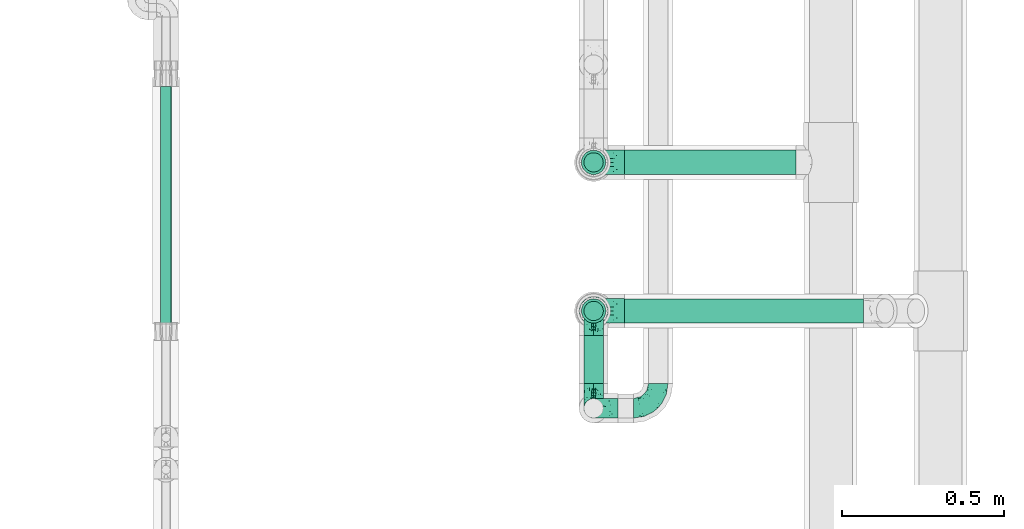
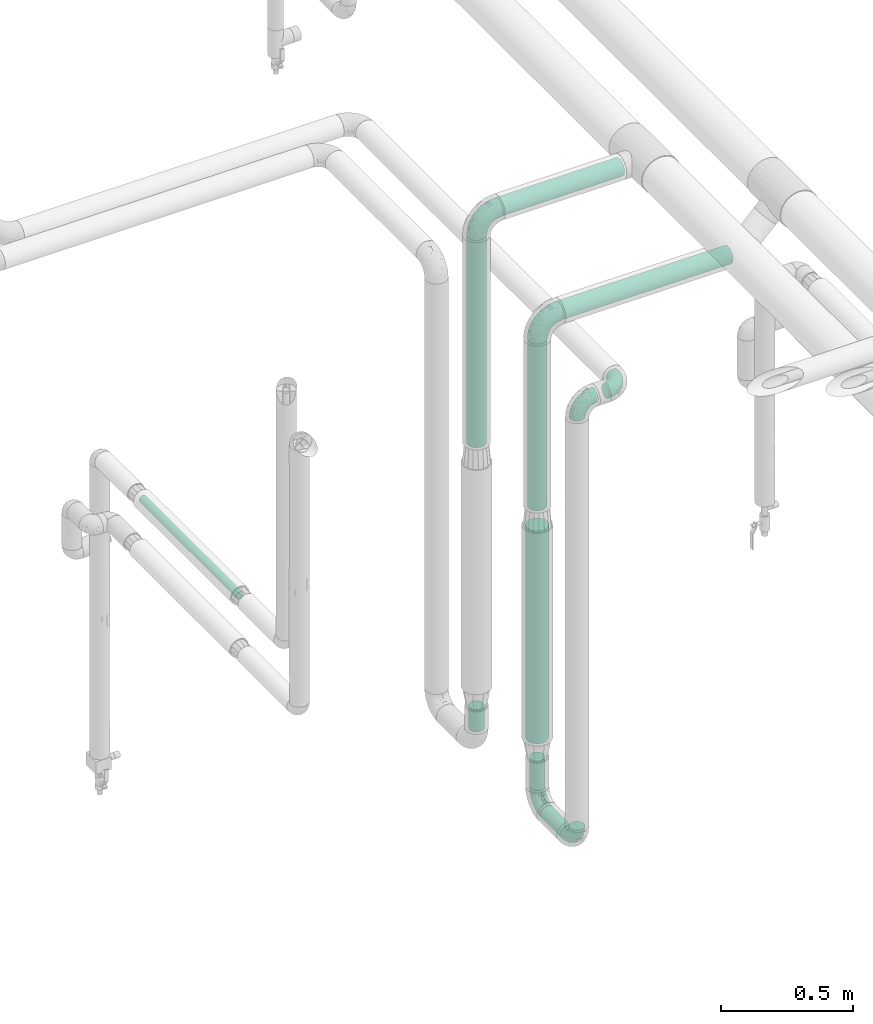
# One storey, part 553 of 827: 9 flow segments, 6 flow fittings.
"""IFC2X3 building model written with IfcOpenShell, lengths in millimetres."""

from ifc_helpers import new_model, entity, si_unit, converted_unit, derived_unit, direction, frame, origin, origin_2d_with_axis, place, context, subcontext, project, spatial, circle, extrude, faceted_brep, source, transform, mapped, material, type_object, type_shapes, element, save


model = new_model("IFC2X3")

# Units and contexts
model_context = context("Model", 3, precision=0.01, world=origin(), true_north=direction((6.12303176911189e-17, 1.0)))
body_context = subcontext(model_context, "Body", "Model", "MODEL_VIEW")
ifc_project = project(units=[si_unit("LENGTHUNIT", "METRE", prefix="MILLI"), si_unit("AREAUNIT", "SQUARE_METRE"), si_unit("VOLUMEUNIT", "CUBIC_METRE"), converted_unit("PLANEANGLEUNIT", "DEGREE", entity("IfcRatioMeasure", 0.0174532925199433), si_unit("PLANEANGLEUNIT", "RADIAN"), dimensions=[0, 0, 0, 0, 0, 0, 0]), si_unit("MASSUNIT", "GRAM", prefix="KILO"), derived_unit("MASSDENSITYUNIT", [(si_unit("MASSUNIT", "GRAM", prefix="KILO"), 1), (si_unit("LENGTHUNIT", "METRE"), -3)]), derived_unit("MOMENTOFINERTIAUNIT", [(si_unit("LENGTHUNIT", "METRE"), 4)]), si_unit("TIMEUNIT", "SECOND"), si_unit("FREQUENCYUNIT", "HERTZ"), si_unit("THERMODYNAMICTEMPERATUREUNIT", "DEGREE_CELSIUS"), derived_unit("THERMALTRANSMITTANCEUNIT", [(si_unit("MASSUNIT", "GRAM", prefix="KILO"), 1), (si_unit("THERMODYNAMICTEMPERATUREUNIT", "KELVIN"), -1), (si_unit("TIMEUNIT", "SECOND"), -3)]), derived_unit("VOLUMETRICFLOWRATEUNIT", [(si_unit("LENGTHUNIT", "METRE"), 3), (si_unit("TIMEUNIT", "SECOND"), -1)]), derived_unit("MASSFLOWRATEUNIT", [(si_unit("MASSUNIT", "GRAM", prefix="KILO"), 1), (si_unit("TIMEUNIT", "SECOND"), -1)]), derived_unit("ROTATIONALFREQUENCYUNIT", [(si_unit("TIMEUNIT", "SECOND"), -1)]), si_unit("ELECTRICCURRENTUNIT", "AMPERE"), si_unit("ELECTRICVOLTAGEUNIT", "VOLT"), si_unit("POWERUNIT", "WATT"), si_unit("FORCEUNIT", "NEWTON", prefix="KILO"), si_unit("ILLUMINANCEUNIT", "LUX"), si_unit("LUMINOUSFLUXUNIT", "LUMEN"), si_unit("LUMINOUSINTENSITYUNIT", "CANDELA"), derived_unit("USERDEFINED", [(si_unit("MASSUNIT", "GRAM", prefix="KILO"), -1), (si_unit("LENGTHUNIT", "METRE"), -2), (si_unit("TIMEUNIT", "SECOND"), 3), (si_unit("LUMINOUSFLUXUNIT", "LUMEN"), 1)]), derived_unit("LINEARVELOCITYUNIT", [(si_unit("LENGTHUNIT", "METRE"), 1), (si_unit("TIMEUNIT", "SECOND"), -1)]), si_unit("PRESSUREUNIT", "PASCAL"), derived_unit("USERDEFINED", [(si_unit("LENGTHUNIT", "METRE"), -2), (si_unit("MASSUNIT", "GRAM", prefix="KILO"), 1), (si_unit("TIMEUNIT", "SECOND"), -2)]), derived_unit("LINEARFORCEUNIT", [(si_unit("MASSUNIT", "GRAM", prefix="KILO"), 1), (si_unit("LENGTHUNIT", "METRE"), 1), (si_unit("TIMEUNIT", "SECOND"), -2), (si_unit("LENGTHUNIT", "METRE"), -1)]), derived_unit("PLANARFORCEUNIT", [(si_unit("MASSUNIT", "GRAM", prefix="KILO"), 1), (si_unit("LENGTHUNIT", "METRE"), 1), (si_unit("TIMEUNIT", "SECOND"), -2), (si_unit("LENGTHUNIT", "METRE"), -2)])], contexts=[model_context])

# Site, building, storey
site_placement = place(None, origin())
site = spatial("IfcSite", under=ifc_project, at=site_placement, CompositionType="ELEMENT")
building_placement = place(site_placement, origin())
building = spatial("IfcBuilding", under=site, at=building_placement, CompositionType="ELEMENT")
storey_placement = place(building_placement, frame((0.0, 0.0, 28200.0)))
storey = spatial("IfcBuildingStorey", under=building, at=storey_placement, Name="08", CompositionType="ELEMENT", Elevation=28200.0)

# Flow segments
pipe_segment_type = type_object("IfcPipeSegmentType", PredefinedType="NOTDEFINED")
flow_segment_1_placement = place(storey_placement, frame((21195.29, 10760.3, 2560.65)))
element("IfcFlowSegment", 1, at=flow_segment_1_placement, inside=storey, type_object=pipe_segment_type, context=body_context, shape_type="SweptSolid", body=[
    extrude(circle(Radius=37.75, at=origin_2d_with_axis()), frame((0.0, 39.35, 39.35), z_axis=(1.0, 0.0, 0.0), x_axis=(0.0, -1.0, 0.0)), (0.0, 0.0, 1.0), 740.186732047182),
])
flow_segment_2_placement = place(storey_placement, frame((21195.05, 11220.3, 2760.65)))
element("IfcFlowSegment", 2, at=flow_segment_2_placement, inside=storey, type_object=pipe_segment_type, context=body_context, shape_type="SweptSolid", body=[
    extrude(circle(Radius=37.75, at=origin_2d_with_axis()), frame((0.0, 39.35, 39.35), z_axis=(1.0, 0.0, 0.0), x_axis=(0.0, 1.0, 0.0)), (0.0, 0.0, 1.0), 532.054122561678),
])
flow_segment_3_placement = place(storey_placement, frame((21060.71, 11220.3, 1745.76)))
element("IfcFlowSegment", 3, at=flow_segment_3_placement, inside=storey, type_object=pipe_segment_type, context=body_context, shape_type="SweptSolid", body=[
    extrude(circle(Radius=37.75, at=origin_2d_with_axis()), frame((39.35, 39.35, 0.0)), (0.0, 0.0, 1.0), 959.235677321025),
])
flow_segment_4_placement = place(storey_placement, frame((21060.95, 10760.3, 1732.85)))
element("IfcFlowSegment", 4, at=flow_segment_4_placement, inside=storey, type_object=pipe_segment_type, context=body_context, shape_type="SweptSolid", body=[
    extrude(circle(Radius=37.75, at=origin_2d_with_axis()), frame((39.35, 39.35, 0.0)), (0.0, 0.0, 1.0), 772.147698373087),
])
flow_segment_5_placement = place(storey_placement, frame((21068.46, 11228.05, 426.01)))
element("IfcFlowSegment", 5, at=flow_segment_5_placement, inside=storey, type_object=pipe_segment_type, context=body_context, shape_type="SweptSolid", body=[
    extrude(circle(Radius=30.0, at=origin_2d_with_axis()), frame((31.6, 31.6, 0.0), z_axis=(0.0, 0.0, 1.0), x_axis=(-1.0, 0.0, 0.0)), (0.0, 0.0, 1.0), 103.990099363139),
])
flow_segment_6_placement = place(storey_placement, frame((21068.7, 10574.33, 326.66)))
element("IfcFlowSegment", 6, at=flow_segment_6_placement, inside=storey, type_object=pipe_segment_type, context=body_context, shape_type="SweptSolid", body=[
    extrude(circle(Radius=30.0, at=origin_2d_with_axis()), frame((31.6, 0.0, 31.6), z_axis=(0.0, 1.0, 0.0), x_axis=(1.0, 0.0, 0.0)), (0.0, 0.0, 1.0), 149.321853330202),
])
flow_segment_7_placement = place(storey_placement, frame((21068.7, 10768.05, 434.26)))
element("IfcFlowSegment", 7, at=flow_segment_7_placement, inside=storey, type_object=pipe_segment_type, context=body_context, shape_type="SweptSolid", body=[
    extrude(circle(Radius=30.0, at=origin_2d_with_axis()), frame((31.6, 31.6, 0.0), z_axis=(0.0, 0.0, 1.0), x_axis=(-1.0, 0.0, 0.0)), (0.0, 0.0, 1.0), 137.000000000008),
])
flow_segment_8_placement = place(storey_placement, frame((19757.92, 10758.58, 1786.23)))
element("IfcFlowSegment", 8, at=flow_segment_8_placement, inside=storey, type_object=pipe_segment_type, context=body_context, shape_type="SweptSolid", body=[
    extrude(circle(Radius=16.75, at=origin_2d_with_axis()), frame((18.35, 0.0, 18.35), z_axis=(0.0, 1.0, 0.0), x_axis=(1.0, 0.0, 0.0)), (0.0, 0.0, 1.0), 736.475142400587),
])
flow_segment_9_placement = place(storey_placement, frame((21054.45, 10753.8, 660.26)))
element("IfcFlowSegment", 9, at=flow_segment_9_placement, inside=storey, type_object=pipe_segment_type, context=body_context, shape_type="SweptSolid", body=[
    extrude(circle(Radius=44.25, at=origin_2d_with_axis()), frame((45.85, 45.85, 0.0), z_axis=(0.0, 0.0, 1.0), x_axis=(-1.0, 0.0, 0.0)), (0.0, 0.0, 1.0), 983.596806403876),
])

# Flow fittings
ifc_material = material()
pipe_fitting_type_1 = type_object("IfcPipeFittingType", Name="ADSK_1", PredefinedType="NOTDEFINED", material=ifc_material)
shared_shape_1 = source(origin(), body_context, "Body", "Brep", [
    faceted_brep([(-76.0, 15.07, -26.11), (-76.0, 7.8, -29.12), (-76.0, 0.0, -30.15), (-76.0, -7.8, -29.12), (-76.0, -15.08, -26.11), (-76.0, -21.32, -21.32), (-76.0, -26.11, -15.08), (-76.0, -29.12, -7.8), (-76.0, -30.15, 0.0), (-76.0, -29.12, 7.8), (-76.0, -26.11, 15.07), (-76.0, -21.32, 21.32), (-76.0, -15.08, 26.11), (-76.0, -7.8, 29.12), (-76.0, 0.0, 30.15), (-76.0, 7.8, 29.12), (-76.0, 15.07, 26.11), (-76.0, 21.32, 21.32), (-76.0, 26.11, 15.07), (-76.0, 29.12, 7.8), (-76.0, 30.15, 0.0), (-76.0, 29.12, -7.8), (-76.0, 26.11, -15.08), (-76.0, 21.32, -21.32), (0.0, 76.0, -30.15), (-7.8, 76.0, -29.12), (-15.07, 76.0, -26.11), (-21.32, 76.0, -21.32), (-26.11, 76.0, -15.08), (-29.12, 76.0, -7.8), (-30.15, 76.0, 0.0), (-29.12, 76.0, 7.8), (-26.11, 76.0, 15.07), (-21.32, 76.0, 21.32), (-15.07, 76.0, 26.11), (-7.8, 76.0, 29.12), (0.0, 76.0, 30.15), (7.8, 76.0, 29.12), (15.08, 76.0, 26.11), (21.32, 76.0, 21.32), (26.11, 76.0, 15.07), (29.12, 76.0, 7.8), (30.15, 76.0, 0.0), (29.12, 76.0, -7.8), (26.11, 76.0, -15.08), (21.32, 76.0, -21.32), (15.08, 76.0, -26.11), (7.8, 76.0, -29.12), (10.79, 31.43, 21.07), (4.32, 31.7, 25.72), (1.65, 15.19, 19.92), (-61.17, -27.8, 0.0), (-51.1, -25.49, 9.84), (-56.14, -10.61, 27.27), (-31.7, -4.32, 25.72), (-39.75, 1.72, 29.41), (-43.2, -24.95, 0.0), (-1.86, 1.86, 0.0), (4.49, 7.65, 5.78), (-7.82, -4.61, 5.83), (-56.21, -22.79, 17.21), (-58.98, -3.38, 29.7), (-53.96, 5.6, 30.07), (-10.86, 10.86, 25.48), (-17.2, -2.6, 20.44), (-49.15, -16.01, 22.7), (-22.18, -14.24, 7.99), (-28.4, -17.42, 0.0), (-13.61, -9.88, 0.0), (-39.0, 23.48, 27.76), (-58.76, 12.54, 28.36), (-41.61, 15.41, 29.48), (16.01, 49.15, 22.7), (-58.55, 25.93, 19.53), (-51.53, 33.5, 13.51), (-64.92, 28.76, 12.4), (-7.48, 23.14, 28.25), (-1.72, 39.75, 29.41), (-12.04, 27.88, 29.88), (-63.91, 18.81, 24.52), (-11.63, 65.16, 28.18), (-4.97, 57.02, 30.05), (9.88, 13.61, 0.0), (-62.5, 31.74, 5.02), (-45.17, 30.98, 21.2), (-21.78, 9.76, 28.58), (10.61, 56.14, 27.27), (-32.09, 54.42, 13.26), (22.79, 56.21, 17.21), (15.38, 31.17, 15.63), (25.49, 51.1, 9.84), (21.84, 36.35, 5.92), (24.95, 43.2, 0.0), (3.38, 58.98, 29.7), (-31.17, -15.38, 15.63), (-39.39, 41.78, 15.45), (-34.56, 41.13, 20.79), (-39.81, -23.25, 5.49), (27.8, 61.17, 0.0), (-31.74, 62.5, 5.02), (-53.07, 36.29, 0.0), (-42.95, 42.95, 7.29), (-36.29, 53.07, 0.0), (-19.83, 58.51, 24.79), (-25.48, 60.2, 19.41), (-14.53, 50.96, 28.57), (-13.31, 37.09, 30.07), (-26.16, 40.06, 26.4), (-32.43, -10.35, 21.9), (17.42, 28.4, 0.0), (14.24, 22.18, 7.99), (-38.67, 9.72, 30.15), (-24.66, 17.36, 30.09), (-37.08, 31.49, 24.99), (-49.27, 22.83, 25.24), (-20.8, 38.81, 28.63), (-27.58, 27.58, 29.2), (-36.07, -20.23, 10.71), (-15.19, -6.16, 14.9), (6.6, 15.4, 14.49), (-2.51, 2.51, 11.35), (-65.16, 11.63, -28.18), (-49.15, -16.01, -22.7), (-57.02, 4.97, -30.05), (-25.93, 58.55, -19.53), (-33.5, 51.53, -13.51), (-28.76, 64.92, -12.4), (-60.2, 25.48, -19.41), (-58.51, 19.83, -24.79), (4.61, 7.82, -5.83), (-7.65, -4.49, -5.78), (-2.51, 2.51, -11.35), (-62.5, 31.74, -5.02), (-50.96, 14.53, -28.57), (-37.09, 13.31, -30.07), (-42.95, 42.95, -7.29), (25.49, 51.1, -9.84), (22.79, 56.21, -17.21), (-40.06, 26.16, -26.4), (3.38, 58.98, -29.7), (-5.6, 53.96, -30.07), (-27.88, 12.04, -29.88), (-9.76, 21.78, -28.58), (-23.14, 7.48, -28.25), (-51.1, -25.49, -9.84), (15.38, 31.17, -15.63), (16.01, 49.15, -22.7), (-23.48, 39.0, -27.76), (-12.54, 58.76, -28.36), (-15.41, 41.61, -29.48), (-56.21, -22.79, -17.21), (-9.72, 38.67, -30.15), (-17.36, 24.66, -30.09), (-22.18, -14.24, -7.99), (-41.13, 34.56, -20.79), (-31.74, 62.5, -5.02), (-58.98, -3.38, -29.7), (-31.17, -15.38, -15.63), (-56.14, -10.61, -27.27), (14.24, 22.18, -7.99), (23.25, 39.81, -5.49), (-31.49, 37.08, -24.99), (-15.19, -6.16, -14.9), (1.65, 15.19, -19.92), (-18.81, 63.91, -24.52), (-32.59, -11.62, -20.84), (-31.7, -4.32, -25.72), (-17.2, -2.6, -20.44), (-39.75, 1.72, -29.41), (-54.42, 32.09, -13.26), (-30.98, 45.17, -21.2), (10.61, 56.14, -27.27), (10.23, 31.31, -21.52), (4.32, 31.7, -25.72), (-41.78, 39.39, -15.45), (-1.72, 39.75, -29.41), (-36.35, -21.84, -5.92), (-22.83, 49.27, -25.24), (-38.81, 20.8, -28.63), (-27.58, 27.58, -29.2), (-10.86, 10.86, -25.48), (20.23, 36.07, -10.71), (6.6, 15.4, -14.49)], [[[0, 1, 2, 3, 4, 5, 6, 7, 8, 9, 10, 11, 12, 13, 14, 15, 16, 17, 18, 19, 20, 21, 22, 23]], [[24, 25, 26, 27, 28, 29, 30, 31, 32, 33, 34, 35, 36, 37, 38, 39, 40, 41, 42, 43, 44, 45, 46, 47]], [[48, 49, 50]], [[51, 52, 9]], [[53, 54, 55]], [[9, 52, 10]], [[56, 52, 51]], [[57, 58, 59]], [[11, 10, 60]], [[14, 61, 62]], [[63, 54, 64]], [[65, 12, 11]], [[65, 53, 12]], [[66, 67, 68]], [[69, 70, 71]], [[72, 39, 38]], [[73, 74, 75]], [[15, 70, 16]], [[76, 77, 78]], [[16, 79, 17]], [[13, 61, 14]], [[35, 80, 81]], [[14, 62, 15]], [[17, 73, 18]], [[57, 82, 58]], [[20, 19, 83]], [[75, 19, 18]], [[70, 15, 62]], [[73, 84, 74]], [[78, 85, 76]], [[38, 86, 72]], [[32, 31, 87]], [[88, 89, 90]], [[91, 92, 90]], [[72, 86, 49]], [[36, 93, 37]], [[75, 83, 19]], [[36, 35, 81]], [[60, 94, 65]], [[40, 90, 41]], [[95, 96, 87]], [[88, 90, 40]], [[66, 97, 67]], [[90, 98, 41]], [[40, 39, 88]], [[99, 31, 30]], [[20, 83, 100]], [[101, 102, 100]], [[52, 60, 10]], [[102, 99, 30]], [[96, 103, 104]], [[83, 101, 100]], [[12, 53, 13]], [[104, 103, 33]], [[105, 106, 81]], [[107, 105, 103]], [[64, 54, 108]], [[80, 103, 105]], [[80, 35, 34]], [[34, 33, 103]], [[86, 38, 37]], [[109, 110, 82]], [[71, 111, 112]], [[69, 107, 113]], [[79, 73, 17]], [[114, 113, 84]], [[33, 32, 104]], [[115, 107, 116]], [[105, 115, 106]], [[93, 81, 77]], [[54, 53, 65]], [[61, 53, 55]], [[108, 94, 64]], [[54, 63, 85]], [[93, 86, 37]], [[77, 76, 49]], [[77, 49, 86]], [[49, 63, 50]], [[60, 52, 117]], [[65, 11, 60]], [[39, 72, 88]], [[89, 88, 72]], [[71, 70, 62]], [[79, 70, 114]], [[103, 96, 107]], [[69, 113, 114]], [[112, 106, 116]], [[77, 81, 106]], [[112, 116, 71]], [[112, 55, 85]], [[64, 50, 63]], [[57, 59, 68]], [[32, 87, 104]], [[96, 104, 87]], [[94, 118, 64]], [[50, 119, 89]], [[50, 64, 118]], [[50, 89, 48]], [[81, 93, 36]], [[86, 93, 77]], [[53, 61, 13]], [[62, 61, 55]], [[71, 62, 111]], [[69, 71, 116]], [[95, 101, 74]], [[99, 101, 87]], [[118, 66, 59]], [[117, 97, 66]], [[117, 66, 94]], [[91, 89, 110]], [[91, 110, 109]], [[110, 89, 119]], [[9, 8, 51]], [[98, 90, 92]], [[98, 42, 41]], [[101, 83, 74]], [[101, 99, 102]], [[87, 31, 99]], [[62, 55, 111]], [[55, 112, 111]], [[107, 69, 116]], [[70, 69, 114]], [[107, 96, 113]], [[84, 113, 96]], [[84, 96, 95]], [[114, 84, 73]], [[70, 79, 16]], [[73, 79, 114]], [[54, 85, 55]], [[76, 85, 63]], [[49, 76, 63]], [[77, 106, 78]], [[106, 112, 78]], [[85, 78, 112]], [[73, 75, 18]], [[83, 75, 74]], [[103, 80, 34]], [[81, 80, 105]], [[101, 95, 87]], [[84, 95, 74]], [[106, 115, 116]], [[105, 107, 115]], [[120, 59, 58]], [[82, 110, 58]], [[119, 58, 110]], [[118, 59, 120]], [[66, 68, 59]], [[54, 65, 108]], [[94, 108, 65]], [[66, 118, 94]], [[50, 118, 120]], [[50, 120, 119]], [[119, 120, 58]], [[89, 72, 48]], [[49, 48, 72]], [[60, 117, 94]], [[117, 52, 97]], [[52, 56, 97]], [[67, 97, 56]], [[92, 91, 109]], [[89, 91, 90]], [[121, 1, 0]], [[122, 5, 4]], [[2, 1, 123]], [[124, 125, 126]], [[127, 128, 23]], [[129, 130, 131]], [[100, 132, 20]], [[133, 134, 123]], [[135, 100, 102]], [[136, 137, 44]], [[133, 128, 138]], [[24, 139, 140]], [[141, 142, 143]], [[121, 128, 133]], [[6, 144, 7]], [[137, 145, 146]], [[144, 51, 7]], [[147, 148, 149]], [[144, 6, 150]], [[149, 151, 152]], [[153, 68, 67]], [[154, 128, 127]], [[30, 155, 102]], [[43, 42, 98]], [[156, 3, 2]], [[157, 144, 150]], [[158, 4, 3]], [[24, 140, 25]], [[155, 135, 102]], [[159, 160, 109]], [[30, 29, 155]], [[147, 138, 161]], [[27, 124, 28]], [[57, 129, 82]], [[162, 163, 131]], [[27, 26, 164]], [[148, 26, 25]], [[165, 166, 167]], [[24, 47, 139]], [[143, 168, 141]], [[22, 21, 169]], [[125, 124, 170]], [[148, 25, 140]], [[46, 146, 171]], [[158, 122, 4]], [[0, 23, 128]], [[1, 121, 123]], [[109, 82, 159]], [[45, 44, 137]], [[146, 46, 45]], [[136, 43, 98]], [[132, 21, 20]], [[136, 98, 92]], [[172, 173, 146]], [[46, 171, 47]], [[43, 136, 44]], [[174, 154, 169]], [[171, 173, 175]], [[6, 5, 150]], [[126, 29, 28]], [[176, 56, 144]], [[122, 158, 166]], [[164, 124, 27]], [[177, 161, 170]], [[23, 22, 127]], [[178, 138, 179]], [[133, 178, 134]], [[156, 123, 168]], [[156, 158, 3]], [[168, 143, 166]], [[168, 166, 158]], [[166, 180, 167]], [[173, 171, 146]], [[139, 171, 175]], [[172, 145, 163]], [[173, 180, 142]], [[5, 122, 150]], [[157, 150, 122]], [[137, 136, 181]], [[146, 45, 137]], [[149, 148, 140]], [[164, 148, 177]], [[128, 154, 138]], [[147, 161, 177]], [[152, 134, 179]], [[168, 123, 134]], [[152, 179, 149]], [[152, 175, 142]], [[57, 130, 129]], [[157, 165, 167]], [[22, 169, 127]], [[154, 127, 169]], [[163, 167, 180]], [[162, 157, 167]], [[173, 163, 180]], [[182, 163, 145]], [[123, 156, 2]], [[158, 156, 168]], [[171, 139, 47]], [[140, 139, 175]], [[149, 140, 151]], [[147, 149, 179]], [[174, 135, 125]], [[132, 135, 169]], [[176, 157, 153]], [[176, 153, 67]], [[153, 157, 162]], [[182, 159, 129]], [[181, 160, 159]], [[181, 159, 145]], [[51, 144, 56]], [[51, 8, 7]], [[135, 132, 100]], [[169, 21, 132]], [[126, 155, 29]], [[135, 155, 125]], [[140, 175, 151]], [[175, 152, 151]], [[138, 147, 179]], [[148, 147, 177]], [[138, 154, 161]], [[170, 161, 154]], [[170, 154, 174]], [[177, 170, 124]], [[148, 164, 26]], [[124, 164, 177]], [[173, 142, 175]], [[143, 142, 180]], [[166, 143, 180]], [[168, 134, 141]], [[134, 152, 141]], [[142, 141, 152]], [[124, 126, 28]], [[155, 126, 125]], [[128, 121, 0]], [[123, 121, 133]], [[135, 174, 169]], [[170, 174, 125]], [[134, 178, 179]], [[133, 138, 178]], [[130, 153, 162]], [[68, 153, 130]], [[57, 68, 130]], [[182, 129, 131]], [[159, 82, 129]], [[157, 122, 165]], [[166, 165, 122]], [[163, 162, 167]], [[162, 131, 130]], [[145, 172, 146]], [[163, 173, 172]], [[159, 182, 145]], [[131, 163, 182]], [[56, 176, 67]], [[157, 176, 144]], [[137, 181, 145]], [[181, 136, 160]], [[136, 92, 160]], [[109, 160, 92]]]),
])
type_shapes(pipe_fitting_type_1, [shared_shape_1])
flow_fitting_placement = place(storey_placement, frame((21300.24, 10498.33, 2400.0)))
element("IfcFlowFitting", 10, at=flow_fitting_placement, inside=storey, type_object=pipe_fitting_type_1, material=ifc_material, Name="ADSK_1", ObjectType="ADSK_1", context=body_context, shape_type="MappedRepresentation", body=[
    mapped(shared_shape_1, transform((0.0, 0.0, 0.0), scale=1.0)),
])
for number, where, z_axis, x_axis, name in (
    (11, (21100.29, 10498.33, 2400.0), (0.0, -1.0, 0.0), (-1.0, 0.0, 0.0), "ADSK_1"),
    (12, (21100.29, 10498.33, 358.26), (1.0, 0.0, 0.0), (0.0, 0.0, -1.0), "ADSK_1"),
    (13, (21100.29, 10799.65, 358.26), (1.0, 0.0, 0.0), (0.0, 1.0, 0.0), "ADSK_1"),
):
    element("IfcFlowFitting", number, at=place(storey_placement, frame(where, z_axis=z_axis, x_axis=x_axis)), inside=storey, type_object=pipe_fitting_type_1, material=ifc_material, Name=name, ObjectType="ADSK_1", context=body_context, shape_type="MappedRepresentation", body=[
        mapped(shared_shape_1, transform((0.0, 0.0, 0.0), scale=1.0)),
    ])
pipe_fitting_type_2 = type_object("IfcPipeFittingType", Name="ADSK_1", PredefinedType="NOTDEFINED", material=ifc_material)
shared_shape_2 = source(origin(), body_context, "Body", "Brep", [
    faceted_brep([(-95.0, 19.02, -32.95), (-95.0, 9.85, -36.75), (-95.0, 0.0, -38.05), (-95.0, -9.85, -36.75), (-95.0, -19.03, -32.95), (-95.0, -26.91, -26.91), (-95.0, -32.95, -19.03), (-95.0, -36.75, -9.85), (-95.0, -38.05, 0.0), (-95.0, -36.75, 9.85), (-95.0, -32.95, 19.02), (-95.0, -26.91, 26.91), (-95.0, -19.03, 32.95), (-95.0, -9.85, 36.75), (-95.0, 0.0, 38.05), (-95.0, 9.85, 36.75), (-95.0, 19.02, 32.95), (-95.0, 26.91, 26.91), (-95.0, 32.95, 19.02), (-95.0, 36.75, 9.85), (-95.0, 38.05, 0.0), (-95.0, 36.75, -9.85), (-95.0, 32.95, -19.03), (-95.0, 26.91, -26.91), (0.0, 95.0, -38.05), (-9.85, 95.0, -36.75), (-19.02, 95.0, -32.95), (-26.91, 95.0, -26.91), (-32.95, 95.0, -19.03), (-36.75, 95.0, -9.85), (-38.05, 95.0, 0.0), (-36.75, 95.0, 9.85), (-32.95, 95.0, 19.02), (-26.91, 95.0, 26.91), (-19.02, 95.0, 32.95), (-9.85, 95.0, 36.75), (0.0, 95.0, 38.05), (9.85, 95.0, 36.75), (19.03, 95.0, 32.95), (26.91, 95.0, 26.91), (32.95, 95.0, 19.02), (36.75, 95.0, 9.85), (38.05, 95.0, 0.0), (36.75, 95.0, -9.85), (32.95, 95.0, -19.03), (26.91, 95.0, -26.91), (19.03, 95.0, -32.95), (9.85, 95.0, -36.75), (-7.99, -4.96, 6.3), (-0.92, 0.92, 0.0), (4.62, 8.1, 8.01), (-76.19, -35.57, 0.0), (-64.32, -32.32, 12.43), (20.51, 62.45, 28.68), (-60.56, -33.52, 0.0), (-70.4, -13.47, 34.42), (-39.61, -5.88, 32.32), (-49.6, 2.07, 37.1), (-70.34, -28.81, 21.71), (14.64, 40.81, 26.5), (5.88, 39.61, 32.32), (3.59, 20.77, 25.31), (-40.45, 68.06, 16.75), (-62.45, -20.51, 28.68), (-44.52, -26.87, 0.0), (-28.47, -20.22, 0.0), (-26.43, -17.83, 8.75), (-76.1, 39.63, 10.76), (-72.74, 37.58, 18.19), (-60.35, 46.18, 14.61), (-13.4, 13.4, 32.12), (-20.77, -3.59, 25.31), (-14.66, 81.47, 35.56), (-6.22, 71.26, 37.92), (-57.5, 42.48, 22.79), (-15.0, 34.74, 37.7), (-27.1, 12.08, 36.05), (-9.2, 28.81, 35.63), (-79.98, 23.7, 30.95), (-73.68, -4.3, 37.48), (-30.74, 21.67, 37.97), (-62.36, 47.59, 6.79), (-72.71, 32.83, 24.69), (-67.42, 7.02, 37.95), (-32.13, 75.27, 24.51), (-43.46, 51.47, 26.26), (-24.98, 73.15, 31.29), (20.59, 41.28, 19.85), (7.79, 16.09, 15.86), (-73.21, 42.39, 0.0), (-54.73, 54.73, 0.0), (-73.44, 15.79, 35.79), (-5.94, 4.32, 20.43), (28.81, 70.34, 21.71), (32.32, 64.32, 12.43), (-53.59, 26.2, 35.09), (-52.02, 19.31, 37.21), (21.38, 33.53, 10.34), (26.87, 44.52, 0.0), (-48.28, 12.14, 38.05), (4.3, 73.68, 37.48), (-44.08, -25.52, 12.79), (-41.28, -20.59, 19.85), (35.57, 76.19, 0.0), (-47.26, 54.3, 20.18), (-47.4, 61.99, 8.58), (-42.39, 73.21, 0.0), (-39.67, 78.86, 7.21), (-45.69, 36.84, 33.11), (-32.83, 50.13, 33.35), (13.47, 70.4, 34.42), (-18.25, 63.73, 36.07), (-40.63, -13.75, 27.22), (-16.63, 46.37, 37.95), (-53.47, 38.79, 28.59), (-26.07, 48.54, 36.15), (-34.51, 34.51, 36.86), (-2.07, 49.6, 37.1), (-22.79, -10.49, 19.23), (-61.73, 28.67, 31.87), (9.65, 14.7, 0.0), (20.22, 28.47, 0.0), (33.52, 60.56, 0.0), (-11.42, -5.44, 13.25), (-14.7, -9.65, 0.0), (-81.47, 14.66, -35.56), (-62.45, -20.51, -28.68), (-71.26, 6.22, -37.92), (-75.27, 32.13, -24.51), (-73.15, 24.98, -31.29), (13.47, 70.4, -34.42), (5.88, 39.61, -32.32), (-2.07, 49.6, -37.1), (-78.86, 39.67, -7.21), (-70.4, -13.47, -34.42), (-39.61, -5.88, -32.32), (-61.99, 47.4, -8.58), (32.32, 64.32, -12.43), (28.81, 70.34, -21.71), (-63.73, 18.25, -36.07), (-50.13, 32.83, -33.35), (4.3, 73.68, -37.48), (-7.02, 67.42, -37.95), (-39.63, 76.1, -10.76), (-46.18, 60.35, -14.61), (-47.59, 62.36, -6.79), (-64.32, -32.32, -12.43), (-26.2, 53.59, -35.09), (-15.79, 73.44, -35.79), (-19.31, 52.02, -37.21), (-37.58, 72.74, -18.19), (-70.34, -28.81, -21.71), (-42.48, 57.5, -22.79), (-38.79, 53.47, -28.59), (-51.47, 43.46, -26.26), (-32.83, 72.71, -24.69), (-46.37, 16.63, -37.95), (-73.68, -4.3, -37.48), (-41.28, -20.59, -19.85), (-44.08, -25.52, -12.79), (13.75, 40.63, -27.22), (20.51, 62.45, -28.68), (-68.06, 40.45, -16.75), (-54.3, 47.26, -20.18), (-12.14, 48.28, -38.05), (-21.67, 30.74, -37.97), (-36.84, 45.69, -33.11), (-11.42, -5.44, -13.25), (7.79, 16.09, -15.86), (4.62, 8.1, -8.01), (-23.7, 79.98, -30.95), (-26.43, -17.83, -8.75), (-7.99, -4.96, -6.3), (-40.81, -14.64, -26.5), (-20.77, -3.59, -25.31), (-34.74, 15.0, -37.7), (-12.08, 27.1, -36.05), (-28.81, 9.2, -35.63), (-22.79, -10.49, -19.23), (21.38, 33.53, -10.34), (20.59, 41.28, -19.85), (-48.54, 26.07, -36.15), (-49.6, 2.07, -37.1), (-13.4, 13.4, -32.12), (3.59, 20.77, -25.31), (-28.67, 61.73, -31.87), (-34.51, 34.51, -36.86), (-5.94, 4.32, -20.43)], [[[0, 1, 2, 3, 4, 5, 6, 7, 8, 9, 10, 11, 12, 13, 14, 15, 16, 17, 18, 19, 20, 21, 22, 23]], [[24, 25, 26, 27, 28, 29, 30, 31, 32, 33, 34, 35, 36, 37, 38, 39, 40, 41, 42, 43, 44, 45, 46, 47]], [[48, 49, 50]], [[51, 52, 9]], [[53, 39, 38]], [[9, 52, 10]], [[54, 52, 51]], [[55, 56, 57]], [[11, 10, 58]], [[59, 60, 61]], [[32, 31, 62]], [[63, 12, 11]], [[63, 55, 12]], [[64, 65, 66]], [[67, 68, 69]], [[70, 56, 71]], [[35, 72, 73]], [[69, 68, 74]], [[75, 76, 77]], [[16, 78, 17]], [[13, 79, 14]], [[76, 75, 80]], [[67, 69, 81]], [[18, 17, 82]], [[14, 79, 83]], [[20, 19, 67]], [[84, 85, 86]], [[87, 61, 88]], [[89, 81, 90]], [[18, 82, 68]], [[15, 91, 16]], [[14, 83, 15]], [[71, 92, 61]], [[17, 78, 82]], [[93, 87, 94]], [[95, 91, 96]], [[97, 98, 94]], [[86, 72, 34]], [[96, 99, 80]], [[37, 36, 100]], [[40, 39, 93]], [[40, 94, 41]], [[64, 66, 101]], [[93, 94, 40]], [[58, 102, 63]], [[94, 103, 41]], [[94, 87, 97]], [[104, 69, 74]], [[34, 33, 86]], [[105, 69, 104]], [[52, 58, 10]], [[106, 107, 30]], [[108, 109, 85]], [[105, 106, 90]], [[53, 110, 60]], [[86, 111, 72]], [[86, 109, 111]], [[33, 84, 86]], [[12, 55, 13]], [[112, 56, 63]], [[110, 38, 37]], [[34, 72, 35]], [[36, 35, 73]], [[111, 113, 73]], [[105, 107, 106]], [[110, 53, 38]], [[74, 114, 85]], [[91, 15, 83]], [[105, 90, 81]], [[107, 62, 31]], [[33, 32, 84]], [[115, 109, 116]], [[111, 115, 113]], [[100, 73, 117]], [[56, 55, 63]], [[79, 55, 57]], [[102, 118, 112]], [[56, 70, 76]], [[100, 110, 37]], [[117, 77, 60]], [[117, 60, 110]], [[60, 70, 61]], [[58, 52, 101]], [[63, 11, 58]], [[39, 53, 93]], [[87, 93, 53]], [[96, 91, 83]], [[78, 91, 119]], [[32, 62, 84]], [[84, 62, 104]], [[86, 85, 109]], [[85, 114, 108]], [[80, 113, 116]], [[117, 73, 113]], [[80, 116, 96]], [[80, 57, 76]], [[71, 112, 118]], [[61, 87, 59]], [[62, 107, 105]], [[97, 120, 121]], [[70, 71, 61]], [[71, 118, 92]], [[73, 100, 36]], [[110, 100, 117]], [[55, 79, 13]], [[83, 79, 57]], [[96, 83, 99]], [[116, 108, 95]], [[50, 97, 88]], [[97, 87, 88]], [[50, 49, 120]], [[122, 94, 98]], [[89, 20, 67]], [[105, 81, 69]], [[89, 67, 81]], [[68, 19, 18]], [[68, 67, 19]], [[74, 68, 82]], [[114, 82, 119]], [[74, 85, 104]], [[82, 114, 74]], [[114, 119, 108]], [[95, 108, 119]], [[116, 109, 108]], [[123, 48, 50]], [[97, 50, 120]], [[123, 50, 88]], [[91, 95, 119]], [[116, 95, 96]], [[84, 104, 85]], [[104, 62, 105]], [[83, 57, 99]], [[57, 80, 99]], [[66, 48, 123]], [[66, 124, 48]], [[118, 66, 123]], [[124, 66, 65]], [[66, 118, 101]], [[54, 64, 52]], [[124, 49, 48]], [[30, 107, 31]], [[91, 78, 16]], [[82, 78, 119]], [[56, 76, 57]], [[77, 76, 70]], [[60, 77, 70]], [[77, 117, 75]], [[117, 113, 75]], [[113, 80, 75]], [[9, 8, 51]], [[103, 94, 122]], [[103, 42, 41]], [[73, 72, 111]], [[113, 115, 116]], [[111, 109, 115]], [[102, 112, 63]], [[71, 56, 112]], [[118, 102, 101]], [[92, 123, 88]], [[123, 92, 118]], [[61, 92, 88]], [[87, 53, 59]], [[60, 59, 53]], [[97, 121, 98]], [[58, 101, 102]], [[64, 101, 52]], [[125, 1, 0]], [[126, 5, 4]], [[2, 1, 127]], [[1, 125, 127]], [[128, 129, 23]], [[130, 131, 132]], [[89, 133, 20]], [[126, 134, 135]], [[136, 89, 90]], [[137, 138, 44]], [[139, 129, 140]], [[24, 141, 142]], [[143, 144, 145]], [[125, 129, 139]], [[6, 146, 7]], [[147, 148, 149]], [[146, 51, 7]], [[143, 150, 144]], [[146, 6, 151]], [[152, 153, 154]], [[126, 4, 134]], [[0, 23, 129]], [[28, 155, 150]], [[43, 42, 103]], [[54, 146, 64]], [[139, 156, 127]], [[157, 3, 2]], [[151, 158, 159]], [[160, 131, 161]], [[22, 21, 162]], [[136, 144, 163]], [[149, 164, 165]], [[24, 142, 25]], [[166, 140, 154]], [[154, 129, 128]], [[143, 30, 29]], [[167, 168, 169]], [[155, 28, 27]], [[26, 170, 27]], [[171, 167, 172]], [[26, 25, 148]], [[27, 170, 155]], [[173, 135, 174]], [[144, 150, 152]], [[175, 176, 177]], [[24, 47, 141]], [[45, 161, 46]], [[148, 25, 142]], [[176, 175, 165]], [[64, 159, 171]], [[138, 45, 44]], [[130, 46, 161]], [[137, 44, 43]], [[178, 159, 158]], [[137, 103, 122]], [[163, 144, 152]], [[136, 133, 89]], [[103, 137, 43]], [[6, 5, 151]], [[178, 158, 173]], [[134, 4, 3]], [[178, 173, 174]], [[137, 98, 179]], [[145, 90, 106]], [[138, 180, 161]], [[46, 130, 47]], [[136, 90, 145]], [[133, 162, 21]], [[23, 22, 128]], [[139, 140, 181]], [[139, 181, 156]], [[157, 127, 182]], [[157, 134, 3]], [[182, 177, 135]], [[182, 135, 134]], [[135, 183, 174]], [[131, 130, 161]], [[141, 130, 132]], [[160, 180, 184]], [[131, 183, 176]], [[5, 126, 151]], [[158, 151, 126]], [[180, 138, 137]], [[161, 45, 138]], [[149, 148, 142]], [[170, 148, 185]], [[22, 162, 128]], [[128, 162, 163]], [[129, 154, 140]], [[154, 153, 166]], [[165, 156, 186]], [[182, 127, 156]], [[165, 186, 149]], [[165, 132, 176]], [[131, 184, 183]], [[187, 167, 178]], [[184, 168, 187]], [[167, 169, 172]], [[184, 180, 168]], [[174, 183, 184]], [[127, 157, 2]], [[134, 157, 182]], [[130, 141, 47]], [[142, 141, 132]], [[149, 142, 164]], [[186, 166, 147]], [[180, 179, 168]], [[169, 179, 120]], [[137, 179, 180]], [[179, 121, 120]], [[106, 30, 143]], [[136, 145, 144]], [[106, 143, 145]], [[150, 29, 28]], [[150, 143, 29]], [[152, 150, 155]], [[153, 155, 185]], [[152, 154, 163]], [[155, 153, 152]], [[153, 185, 166]], [[147, 166, 185]], [[186, 140, 166]], [[169, 120, 49]], [[169, 49, 172]], [[179, 169, 168]], [[148, 147, 185]], [[186, 147, 149]], [[128, 163, 154]], [[163, 162, 136]], [[142, 132, 164]], [[132, 165, 164]], [[171, 124, 65]], [[124, 171, 172]], [[64, 146, 159]], [[171, 159, 178]], [[171, 65, 64]], [[172, 49, 124]], [[162, 133, 136]], [[20, 133, 21]], [[148, 170, 26]], [[155, 170, 185]], [[131, 176, 132]], [[177, 176, 183]], [[135, 177, 183]], [[177, 182, 175]], [[182, 156, 175]], [[156, 165, 175]], [[51, 146, 54]], [[51, 8, 7]], [[129, 125, 0]], [[127, 125, 139]], [[140, 186, 181]], [[156, 181, 186]], [[158, 126, 173]], [[135, 173, 126]], [[187, 178, 174]], [[171, 178, 167]], [[184, 187, 174]], [[167, 187, 168]], [[180, 160, 161]], [[184, 131, 160]], [[98, 137, 122]], [[98, 121, 179]], [[151, 159, 146]]]),
])
type_shapes(pipe_fitting_type_2, [shared_shape_2])
for number, where, z_axis, x_axis, name in (
    (14, (21100.05, 11259.65, 2800.0), (0.0, -1.0, 0.0), (-1.0, 0.0, 0.0), "ADSK_1"),
    (15, (21100.29, 10799.65, 2600.0), (0.0, -1.0, 0.0), (-1.0, 0.0, 0.0), "ADSK_1"),
):
    element("IfcFlowFitting", number, at=place(storey_placement, frame(where, z_axis=z_axis, x_axis=x_axis)), inside=storey, type_object=pipe_fitting_type_2, material=ifc_material, Name=name, ObjectType="ADSK_1", context=body_context, shape_type="MappedRepresentation", body=[
        mapped(shared_shape_2, transform((0.0, 0.0, 0.0), scale=1.0)),
    ])

save(model, "model.ifc")
